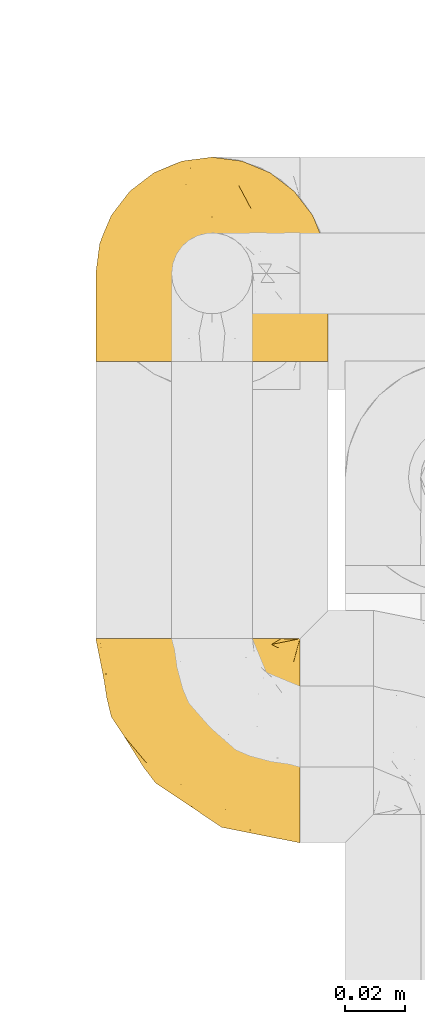
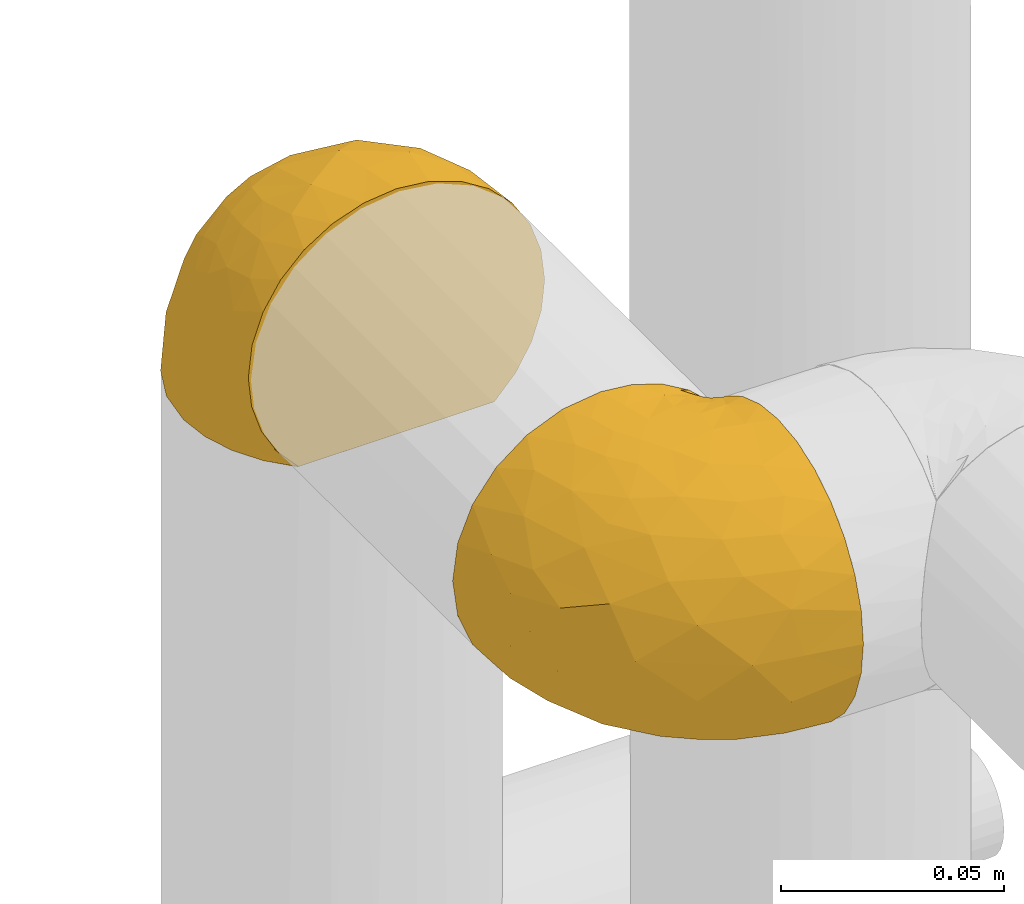
# One storey, part 83 of 827: 2 coverings.
"""IFC2X3 building model written with IfcOpenShell, lengths in millimetres."""

from ifc_helpers import new_model, entity, si_unit, converted_unit, derived_unit, direction, frame, origin, place, context, subcontext, project, spatial, faceted_brep, element, save


model = new_model("IFC2X3")

# Units and contexts
model_context = context("Model", 3, precision=0.01, world=origin(), true_north=direction((6.12303176911189e-17, 1.0)))
body_context = subcontext(model_context, "Body", "Model", "MODEL_VIEW")
ifc_project = project(units=[si_unit("LENGTHUNIT", "METRE", prefix="MILLI"), si_unit("AREAUNIT", "SQUARE_METRE"), si_unit("VOLUMEUNIT", "CUBIC_METRE"), converted_unit("PLANEANGLEUNIT", "DEGREE", entity("IfcRatioMeasure", 0.0174532925199433), si_unit("PLANEANGLEUNIT", "RADIAN"), dimensions=[0, 0, 0, 0, 0, 0, 0]), si_unit("MASSUNIT", "GRAM", prefix="KILO"), derived_unit("MASSDENSITYUNIT", [(si_unit("MASSUNIT", "GRAM", prefix="KILO"), 1), (si_unit("LENGTHUNIT", "METRE"), -3)]), derived_unit("MOMENTOFINERTIAUNIT", [(si_unit("LENGTHUNIT", "METRE"), 4)]), si_unit("TIMEUNIT", "SECOND"), si_unit("FREQUENCYUNIT", "HERTZ"), si_unit("THERMODYNAMICTEMPERATUREUNIT", "DEGREE_CELSIUS"), derived_unit("THERMALTRANSMITTANCEUNIT", [(si_unit("MASSUNIT", "GRAM", prefix="KILO"), 1), (si_unit("THERMODYNAMICTEMPERATUREUNIT", "KELVIN"), -1), (si_unit("TIMEUNIT", "SECOND"), -3)]), derived_unit("VOLUMETRICFLOWRATEUNIT", [(si_unit("LENGTHUNIT", "METRE"), 3), (si_unit("TIMEUNIT", "SECOND"), -1)]), derived_unit("MASSFLOWRATEUNIT", [(si_unit("MASSUNIT", "GRAM", prefix="KILO"), 1), (si_unit("TIMEUNIT", "SECOND"), -1)]), derived_unit("ROTATIONALFREQUENCYUNIT", [(si_unit("TIMEUNIT", "SECOND"), -1)]), si_unit("ELECTRICCURRENTUNIT", "AMPERE"), si_unit("ELECTRICVOLTAGEUNIT", "VOLT"), si_unit("POWERUNIT", "WATT"), si_unit("FORCEUNIT", "NEWTON", prefix="KILO"), si_unit("ILLUMINANCEUNIT", "LUX"), si_unit("LUMINOUSFLUXUNIT", "LUMEN"), si_unit("LUMINOUSINTENSITYUNIT", "CANDELA"), derived_unit("USERDEFINED", [(si_unit("MASSUNIT", "GRAM", prefix="KILO"), -1), (si_unit("LENGTHUNIT", "METRE"), -2), (si_unit("TIMEUNIT", "SECOND"), 3), (si_unit("LUMINOUSFLUXUNIT", "LUMEN"), 1)]), derived_unit("LINEARVELOCITYUNIT", [(si_unit("LENGTHUNIT", "METRE"), 1), (si_unit("TIMEUNIT", "SECOND"), -1)]), si_unit("PRESSUREUNIT", "PASCAL"), derived_unit("USERDEFINED", [(si_unit("LENGTHUNIT", "METRE"), -2), (si_unit("MASSUNIT", "GRAM", prefix="KILO"), 1), (si_unit("TIMEUNIT", "SECOND"), -2)]), derived_unit("LINEARFORCEUNIT", [(si_unit("MASSUNIT", "GRAM", prefix="KILO"), 1), (si_unit("LENGTHUNIT", "METRE"), 1), (si_unit("TIMEUNIT", "SECOND"), -2), (si_unit("LENGTHUNIT", "METRE"), -1)]), derived_unit("PLANARFORCEUNIT", [(si_unit("MASSUNIT", "GRAM", prefix="KILO"), 1), (si_unit("LENGTHUNIT", "METRE"), 1), (si_unit("TIMEUNIT", "SECOND"), -2), (si_unit("LENGTHUNIT", "METRE"), -2)])], contexts=[model_context])

# Site, building, storey
site_placement = place(None, origin())
site = spatial("IfcSite", under=ifc_project, at=site_placement, CompositionType="ELEMENT")
building_placement = place(site_placement, origin())
building = spatial("IfcBuilding", under=site, at=building_placement, CompositionType="ELEMENT")
storey_placement = place(building_placement, frame((0.0, 0.0, 28200.0)))
storey = spatial("IfcBuildingStorey", under=building, at=storey_placement, Name="08", CompositionType="ELEMENT", Elevation=28200.0)

# Coverings
covering_1_placement = place(storey_placement, frame((19653.72, 11698.51, 1518.12)))
element("IfcCovering", 1, at=covering_1_placement, inside=storey, Name=":ADSK_", ObjectType=":ADSK_", PredefinedType="INSULATION", context=body_context, shape_type="Brep", body=[
    faceted_brep([(69.15, 23.36, 74.68), (69.15, 16.07, 70.1), (69.15, 9.98, 64.01), (69.15, 5.4, 56.72), (69.15, 2.56, 48.6), (69.15, 1.6, 40.05), (69.15, 2.56, 31.49), (69.15, 5.41, 23.36), (69.15, 9.99, 16.07), (69.15, 16.08, 9.98), (69.15, 23.37, 5.4), (69.15, 31.49, 2.56), (69.15, 40.05, 1.6), (69.15, 48.15, 2.46), (69.15, 55.88, 5.01), (69.15, 62.9, 9.13), (69.15, 68.89, 14.62), (69.15, 68.89, 16.82), (69.15, 68.89, 18.56), (69.15, 68.89, 20.52), (69.15, 68.89, 22.49), (69.15, 68.89, 24.46), (69.15, 68.89, 26.42), (69.15, 68.89, 28.39), (69.15, 68.89, 30.36), (69.15, 68.89, 32.55), (69.15, 68.89, 34.75), (69.15, 68.89, 36.94), (69.15, 68.89, 39.13), (69.15, 68.89, 41.33), (69.15, 68.89, 43.52), (69.15, 68.89, 45.72), (69.15, 68.89, 47.91), (69.15, 68.89, 50.11), (69.15, 68.89, 52.3), (69.15, 68.89, 54.49), (69.15, 68.89, 56.69), (69.15, 68.89, 58.88), (69.15, 68.89, 61.08), (69.15, 68.89, 63.27), (69.15, 68.89, 65.47), (69.15, 62.89, 70.97), (69.15, 55.86, 75.09), (69.15, 48.13, 77.64), (69.15, 40.05, 78.5), (69.15, 31.49, 77.53), (68.89, 69.15, 14.62), (62.89, 69.15, 9.12), (55.87, 69.15, 5.0), (48.14, 69.15, 2.46), (40.05, 69.15, 1.6), (30.09, 69.15, 2.91), (20.82, 69.15, 6.75), (12.86, 69.15, 12.86), (6.75, 69.15, 20.82), (2.91, 69.15, 30.09), (1.6, 69.15, 40.05), (2.91, 69.15, 50.0), (6.75, 69.15, 59.27), (12.86, 69.15, 67.23), (20.82, 69.15, 73.34), (30.09, 69.15, 77.19), (40.05, 69.15, 78.5), (48.14, 69.15, 77.63), (55.87, 69.15, 75.09), (62.89, 69.15, 70.97), (68.89, 69.15, 65.47), (68.89, 69.15, 63.27), (68.89, 69.15, 62.29), (68.89, 69.15, 60.7), (68.89, 69.15, 59.11), (68.89, 69.15, 57.52), (68.89, 69.15, 55.93), (68.89, 69.15, 54.34), (68.89, 69.15, 52.76), (68.89, 69.15, 51.17), (68.89, 69.15, 49.58), (68.89, 69.15, 47.99), (68.89, 69.15, 46.4), (68.89, 69.15, 44.81), (68.89, 69.15, 43.22), (68.89, 69.15, 41.63), (68.89, 69.15, 40.05), (68.89, 69.15, 38.46), (68.89, 69.15, 36.87), (68.89, 69.15, 35.28), (68.89, 69.15, 33.69), (68.89, 69.15, 32.1), (68.89, 69.15, 30.51), (68.89, 69.15, 28.92), (68.89, 69.15, 27.33), (68.89, 69.15, 25.37), (68.89, 69.15, 23.4), (68.89, 69.15, 21.21), (68.89, 69.15, 19.01), (68.89, 69.15, 16.82), (68.97, 68.96, 42.32), (68.96, 68.97, 44.02), (68.97, 68.97, 47.13), (68.97, 68.97, 48.74), (68.98, 68.95, 23.57), (68.97, 68.96, 25.13), (68.96, 68.98, 61.34), (68.96, 68.97, 22.02), (68.96, 68.97, 29.72), (68.96, 68.98, 56.73), (68.96, 68.97, 55.14), (68.96, 68.97, 37.66), (69.0, 68.94, 64.12), (68.96, 68.98, 28.13), (68.96, 68.98, 26.62), (68.97, 68.96, 31.46), (68.96, 68.97, 16.16), (68.96, 68.98, 39.16), (68.96, 68.98, 50.37), (68.97, 68.97, 17.69), (68.97, 68.96, 19.17), (68.97, 68.97, 62.78), (68.96, 68.97, 58.35), (68.96, 68.98, 45.53), (68.97, 68.96, 59.91), (68.97, 68.97, 65.47), (69.02, 68.94, 65.47), (69.08, 68.92, 65.47), (68.97, 68.97, 14.62), (68.94, 69.02, 14.62), (68.92, 69.08, 14.62), (68.96, 68.98, 20.59), (68.96, 68.97, 32.99), (68.95, 68.98, 34.48), (68.96, 68.97, 51.91), (68.92, 69.08, 65.47), (68.94, 69.02, 65.47), (68.98, 68.96, 53.48), (69.08, 68.92, 14.62), (69.02, 68.94, 14.62), (68.96, 68.97, 40.77), (68.97, 68.96, 35.97), (61.33, 67.02, 7.84), (53.1, 63.33, 3.53), (63.33, 64.61, 8.32), (49.27, 49.27, 1.6), (55.53, 51.4, 2.19), (54.6, 43.94, 1.6), (41.99, 61.87, 1.6), (57.07, 61.54, 4.57), (57.95, 57.95, 3.96), (51.56, 56.12, 2.28), (41.58, 63.4, 1.6), (61.7, 65.41, 7.69), (63.33, 53.1, 3.53), (65.0, 63.04, 8.32), (67.02, 61.33, 7.84), (61.87, 41.99, 1.6), (43.94, 54.6, 1.6), (61.21, 56.6, 4.34), (63.4, 41.58, 1.6), (33.11, 13.72, 29.63), (52.82, 5.82, 27.34), (43.3, 6.74, 40.05), (33.73, 58.82, 2.39), (36.52, 51.58, 2.43), (24.87, 42.09, 9.07), (14.17, 46.12, 16.64), (18.43, 55.56, 9.54), (28.67, 52.38, 4.52), (26.0, 61.54, 4.52), (49.25, 23.76, 7.49), (59.72, 20.5, 7.49), (55.1, 14.64, 12.85), (44.72, 41.77, 2.35), (34.15, 16.28, 22.66), (5.25, 49.4, 32.9), (6.75, 52.34, 25.33), (55.54, 4.3, 40.05), (10.47, 58.67, 16.64), (25.49, 25.26, 19.99), (35.53, 20.17, 16.37), (48.22, 34.7, 3.26), (58.71, 28.67, 3.75), (57.42, 8.62, 19.58), (34.84, 33.37, 7.5), (36.87, 41.35, 4.04), (45.01, 17.15, 13.94), (44.4, 12.68, 19.58), (23.96, 21.47, 28.21), (11.2, 41.11, 24.75), (10.56, 37.53, 31.42), (16.81, 30.64, 26.2), (17.38, 26.66, 33.36), (21.38, 21.38, 40.05), (32.34, 14.06, 40.05), (4.3, 55.54, 40.05), (20.65, 35.17, 16.14), (29.66, 29.04, 12.85), (39.6, 24.34, 10.47), (42.55, 29.33, 6.49), (6.74, 43.3, 40.05), (14.06, 32.34, 40.05), (26.84, 57.75, 75.57), (5.28, 49.41, 47.37), (18.52, 27.85, 52.91), (33.13, 13.7, 50.46), (55.1, 14.63, 67.23), (57.43, 8.61, 60.5), (20.72, 48.85, 70.55), (11.46, 54.13, 63.45), (17.69, 37.84, 62.61), (49.26, 23.75, 72.6), (59.73, 20.49, 72.6), (58.71, 28.66, 76.34), (29.72, 20.83, 59.34), (35.35, 55.15, 77.76), (43.94, 54.6, 78.5), (41.99, 61.87, 78.5), (63.4, 41.58, 78.5), (4.93, 57.58, 53.16), (17.46, 59.91, 70.55), (10.94, 36.94, 48.88), (8.92, 45.72, 54.76), (52.83, 5.82, 52.74), (29.34, 37.91, 71.93), (30.26, 50.18, 75.79), (44.4, 12.67, 60.5), (39.06, 49.29, 77.86), (43.06, 42.64, 77.64), (54.6, 43.94, 78.5), (49.27, 49.27, 78.5), (42.69, 19.45, 67.23), (48.2, 34.7, 76.82), (61.87, 41.99, 78.5), (33.44, 62.29, 77.8), (29.67, 29.01, 67.23), (38.5, 31.47, 73.2), (23.35, 37.18, 67.66), (34.97, 43.45, 75.99), (53.1, 63.33, 76.57), (59.68, 67.23, 73.21), (62.19, 66.07, 71.93), (64.11, 65.22, 71.07), (57.97, 61.99, 75.09), (57.95, 57.95, 76.13), (63.33, 53.09, 76.57), (51.77, 56.84, 77.69), (67.02, 61.33, 72.26), (64.98, 63.06, 71.77), (55.53, 51.41, 77.9), (61.22, 56.61, 75.75)], [[[0, 1, 2, 3, 4, 5, 6, 7, 8, 9, 10, 11, 12, 13, 14, 15, 16, 17, 18, 19, 20, 21, 22, 23, 24, 25, 26, 27, 28, 29, 30, 31, 32, 33, 34, 35, 36, 37, 38, 39, 40, 41, 42, 43, 44, 45]], [[46, 47, 48, 49, 50, 51, 52, 53, 54, 55, 56, 57, 58, 59, 60, 61, 62, 63, 64, 65, 66, 67, 68, 69, 70, 71, 72, 73, 74, 75, 76, 77, 78, 79, 80, 81, 82, 83, 84, 85, 86, 87, 88, 89, 90, 91, 92, 93, 94, 95]], [[96, 97, 30]], [[98, 77, 99]], [[100, 101, 21]], [[69, 68, 102]], [[20, 19, 103]], [[24, 23, 104]], [[20, 103, 100]], [[72, 105, 106]], [[84, 83, 107]], [[89, 88, 104]], [[108, 67, 66]], [[109, 110, 90]], [[111, 25, 24]], [[112, 17, 16]], [[82, 113, 83]], [[109, 23, 22]], [[114, 76, 75]], [[105, 36, 106]], [[104, 111, 24]], [[18, 115, 116]], [[97, 96, 80]], [[67, 108, 117]], [[105, 71, 118]], [[31, 97, 119]], [[102, 120, 69]], [[108, 121, 122, 123, 40]], [[112, 95, 115]], [[17, 115, 18]], [[94, 116, 115]], [[117, 68, 67]], [[38, 117, 39]], [[112, 124, 125, 126, 46]], [[17, 112, 115]], [[70, 120, 118]], [[39, 117, 108]], [[120, 38, 37]], [[120, 37, 118]], [[120, 70, 69]], [[116, 94, 127]], [[128, 86, 129]], [[117, 38, 102]], [[74, 130, 75]], [[99, 33, 32]], [[115, 95, 94]], [[39, 108, 40]], [[108, 66, 131, 132, 121]], [[105, 72, 71]], [[118, 37, 36]], [[71, 70, 118]], [[35, 106, 36]], [[36, 105, 118]], [[35, 133, 106]], [[74, 73, 133]], [[106, 133, 73]], [[99, 114, 33]], [[133, 35, 34]], [[73, 72, 106]], [[95, 112, 46]], [[112, 16, 134, 135, 124]], [[130, 114, 75]], [[99, 76, 114]], [[114, 130, 33]], [[34, 33, 130]], [[78, 77, 98]], [[98, 119, 78]], [[130, 133, 34]], [[133, 130, 74]], [[79, 97, 80]], [[98, 99, 32]], [[98, 32, 31]], [[77, 76, 99]], [[97, 79, 119]], [[136, 96, 29]], [[30, 97, 31]], [[136, 29, 28]], [[81, 80, 96]], [[29, 96, 30]], [[31, 119, 98]], [[119, 79, 78]], [[96, 136, 81]], [[82, 81, 136]], [[113, 107, 83]], [[84, 107, 137]], [[107, 27, 137]], [[113, 28, 107]], [[27, 107, 28]], [[85, 84, 137]], [[137, 27, 26]], [[113, 136, 28]], [[136, 113, 82]], [[109, 89, 104]], [[86, 85, 129]], [[89, 109, 90]], [[111, 87, 128]], [[26, 129, 137]], [[88, 111, 104]], [[25, 111, 128]], [[22, 110, 109]], [[23, 109, 104]], [[110, 91, 90]], [[100, 92, 101]], [[110, 22, 101]], [[91, 110, 101]], [[116, 19, 18]], [[111, 88, 87]], [[127, 103, 19]], [[25, 128, 26]], [[86, 128, 87]], [[128, 129, 26]], [[137, 129, 85]], [[120, 102, 38]], [[117, 102, 68]], [[91, 101, 92]], [[21, 101, 22]], [[93, 92, 103]], [[100, 21, 20]], [[100, 103, 92]], [[127, 93, 103]], [[93, 127, 94]], [[116, 127, 19]], [[126, 138, 47]], [[48, 138, 139]], [[140, 125, 124]], [[141, 142, 143]], [[144, 49, 139]], [[145, 140, 146]], [[48, 139, 49]], [[139, 145, 147]], [[49, 144, 148, 50]], [[126, 125, 149]], [[14, 13, 150]], [[151, 146, 140]], [[149, 140, 145]], [[152, 151, 135]], [[152, 14, 150]], [[16, 15, 134]], [[13, 153, 150]], [[124, 151, 140]], [[141, 147, 142]], [[14, 152, 15]], [[15, 152, 134]], [[47, 46, 126]], [[139, 154, 144]], [[138, 48, 47]], [[125, 140, 149]], [[135, 134, 152]], [[146, 155, 142]], [[145, 146, 147]], [[149, 139, 138]], [[147, 141, 154]], [[147, 146, 142]], [[139, 147, 154]], [[139, 149, 145]], [[149, 138, 126]], [[155, 146, 151]], [[150, 143, 142]], [[152, 155, 151]], [[150, 142, 155]], [[13, 12, 156, 153]], [[153, 143, 150]], [[152, 150, 155]], [[151, 124, 135]], [[157, 158, 159]], [[160, 154, 161]], [[162, 163, 164]], [[165, 166, 160]], [[167, 168, 169]], [[141, 170, 161]], [[156, 12, 11]], [[158, 157, 171]], [[172, 55, 173]], [[158, 6, 174]], [[175, 54, 53]], [[52, 166, 164]], [[52, 164, 53]], [[54, 175, 173]], [[166, 52, 51]], [[176, 177, 171]], [[178, 143, 179]], [[156, 11, 179]], [[8, 7, 180]], [[169, 9, 8]], [[179, 143, 153, 156]], [[179, 11, 10]], [[168, 179, 10]], [[181, 162, 182]], [[179, 167, 178]], [[183, 184, 177]], [[183, 169, 184]], [[176, 171, 185]], [[172, 186, 187]], [[158, 7, 6]], [[159, 158, 174]], [[184, 180, 158]], [[54, 173, 55]], [[180, 169, 8]], [[188, 189, 187]], [[9, 168, 10]], [[186, 188, 187]], [[190, 157, 159, 191]], [[55, 172, 192]], [[176, 193, 194]], [[161, 170, 182]], [[162, 164, 165]], [[175, 164, 163]], [[51, 50, 148]], [[167, 195, 196]], [[178, 182, 170]], [[6, 5, 174]], [[158, 180, 7]], [[169, 180, 184]], [[169, 168, 9]], [[179, 168, 167]], [[182, 162, 165]], [[162, 194, 193]], [[161, 165, 160]], [[195, 181, 196]], [[192, 172, 197]], [[192, 56, 55]], [[189, 190, 198]], [[198, 197, 187]], [[172, 187, 197]], [[185, 189, 188]], [[198, 187, 189]], [[186, 172, 173]], [[173, 163, 186]], [[193, 186, 163]], [[176, 185, 188]], [[185, 157, 190]], [[188, 186, 193]], [[177, 176, 194]], [[188, 193, 176]], [[162, 193, 163]], [[195, 177, 194]], [[171, 177, 184]], [[181, 195, 194]], [[183, 167, 169]], [[162, 181, 194]], [[196, 182, 178]], [[158, 171, 184]], [[171, 157, 185]], [[177, 195, 183]], [[167, 183, 195]], [[182, 196, 181]], [[178, 170, 143]], [[178, 167, 196]], [[164, 175, 53]], [[173, 175, 163]], [[160, 51, 148]], [[164, 166, 165]], [[51, 160, 166]], [[160, 148, 144, 154]], [[141, 161, 154]], [[182, 165, 161]], [[190, 189, 185]], [[143, 170, 141]], [[60, 199, 61]], [[197, 200, 192]], [[201, 190, 202]], [[200, 57, 192]], [[203, 204, 2]], [[205, 206, 207]], [[208, 209, 210]], [[211, 207, 201]], [[212, 213, 214]], [[45, 215, 210]], [[216, 206, 58]], [[45, 44, 215]], [[59, 217, 60]], [[60, 217, 199]], [[0, 45, 210]], [[218, 201, 219]], [[202, 159, 220]], [[205, 221, 222]], [[223, 204, 203]], [[1, 203, 2]], [[57, 200, 216]], [[220, 3, 204]], [[220, 174, 4]], [[1, 0, 209]], [[212, 224, 213]], [[225, 226, 227]], [[228, 223, 203]], [[208, 210, 229]], [[210, 226, 229]], [[3, 220, 4]], [[58, 206, 59]], [[209, 203, 1]], [[202, 220, 223]], [[228, 203, 208]], [[202, 211, 201]], [[3, 2, 204]], [[202, 190, 191, 159]], [[210, 215, 230, 226]], [[199, 212, 231]], [[232, 233, 221]], [[233, 208, 229]], [[207, 206, 219]], [[217, 206, 205]], [[227, 224, 225]], [[233, 232, 228]], [[201, 207, 219]], [[234, 232, 221]], [[218, 219, 200]], [[202, 223, 211]], [[174, 220, 159]], [[174, 5, 4]], [[61, 231, 62]], [[220, 204, 223]], [[210, 209, 0]], [[203, 209, 208]], [[225, 233, 229]], [[224, 227, 213]], [[221, 233, 235]], [[57, 56, 192]], [[198, 218, 197]], [[200, 219, 216]], [[201, 198, 190]], [[197, 218, 200]], [[198, 201, 218]], [[206, 216, 219]], [[58, 57, 216]], [[231, 212, 214]], [[222, 212, 199]], [[228, 211, 223]], [[207, 211, 232]], [[62, 231, 214]], [[199, 231, 61]], [[233, 228, 208]], [[211, 228, 232]], [[222, 221, 235]], [[234, 205, 207]], [[206, 217, 59]], [[199, 217, 205]], [[205, 222, 199]], [[224, 222, 235]], [[222, 224, 212]], [[224, 235, 225]], [[233, 225, 235]], [[226, 225, 229]], [[205, 234, 221]], [[207, 232, 234]], [[63, 214, 236]], [[214, 213, 236]], [[214, 63, 62]], [[237, 236, 238]], [[238, 132, 131]], [[236, 237, 64]], [[239, 240, 241]], [[63, 236, 64]], [[131, 66, 65]], [[237, 131, 65]], [[242, 230, 43]], [[237, 65, 64]], [[239, 121, 132]], [[42, 242, 43]], [[241, 240, 243]], [[41, 123, 244]], [[43, 230, 215, 44]], [[244, 122, 245]], [[227, 246, 243]], [[241, 243, 246]], [[121, 239, 245]], [[41, 40, 123]], [[132, 238, 239]], [[244, 42, 41]], [[131, 237, 238]], [[240, 239, 238]], [[245, 239, 241]], [[247, 241, 246]], [[247, 244, 245]], [[238, 236, 240]], [[243, 236, 213]], [[236, 243, 240]], [[226, 246, 227]], [[243, 213, 227]], [[226, 242, 246]], [[241, 247, 245]], [[246, 242, 247]], [[244, 247, 242]], [[242, 226, 230]], [[42, 244, 242]], [[122, 244, 123]], [[122, 121, 245]]]),
])
covering_2_placement = place(storey_placement, frame((19653.72, 11857.86, 1527.47)))
element("IfcCovering", 2, at=covering_2_placement, inside=storey, Name=":ADSK_", ObjectType=":ADSK_", PredefinedType="INSULATION", context=body_context, shape_type="Brep", body=[
    faceted_brep([(74.68, 1.6, 47.38), (70.1, 1.6, 54.67), (64.01, 1.6, 60.76), (56.72, 1.6, 65.34), (48.6, 1.6, 68.18), (40.05, 1.6, 69.15), (31.49, 1.6, 68.18), (23.36, 1.6, 65.33), (16.07, 1.6, 60.75), (9.98, 1.6, 54.66), (5.4, 1.6, 47.37), (2.56, 1.6, 39.25), (1.6, 1.6, 30.7), (2.46, 1.6, 22.59), (5.01, 1.6, 14.86), (9.13, 1.6, 7.84), (14.62, 1.6, 1.85), (16.82, 1.6, 1.85), (18.56, 1.6, 1.85), (20.52, 1.6, 1.85), (22.49, 1.6, 1.85), (24.46, 1.6, 1.85), (26.42, 1.6, 1.85), (28.39, 1.6, 1.85), (30.36, 1.6, 1.85), (32.55, 1.6, 1.85), (34.75, 1.6, 1.85), (36.94, 1.6, 1.85), (39.13, 1.6, 1.85), (41.33, 1.6, 1.85), (43.52, 1.6, 1.85), (45.72, 1.6, 1.85), (47.91, 1.6, 1.85), (50.11, 1.6, 1.85), (52.3, 1.6, 1.85), (54.49, 1.6, 1.85), (56.69, 1.6, 1.85), (58.88, 1.6, 1.85), (61.08, 1.6, 1.85), (63.27, 1.6, 1.85), (65.47, 1.6, 1.85), (70.97, 1.6, 7.85), (75.09, 1.6, 14.88), (77.64, 1.6, 22.61), (78.5, 1.6, 30.7), (77.53, 1.6, 39.26), (14.62, 1.85, 1.6), (9.12, 7.85, 1.6), (5.0, 14.87, 1.6), (2.46, 22.6, 1.6), (1.6, 30.7, 1.6), (2.91, 40.65, 1.6), (6.75, 49.92, 1.6), (12.86, 57.88, 1.6), (20.82, 63.99, 1.6), (30.09, 67.84, 1.6), (40.05, 69.15, 1.6), (50.0, 67.84, 1.6), (59.27, 63.99, 1.6), (67.23, 57.88, 1.6), (73.34, 49.92, 1.6), (77.19, 40.65, 1.6), (78.5, 30.7, 1.6), (77.63, 22.6, 1.6), (75.09, 14.87, 1.6), (70.97, 7.85, 1.6), (65.47, 1.85, 1.6), (63.27, 1.85, 1.6), (62.29, 1.85, 1.6), (60.7, 1.85, 1.6), (59.11, 1.85, 1.6), (57.52, 1.85, 1.6), (55.93, 1.85, 1.6), (54.34, 1.85, 1.6), (52.76, 1.85, 1.6), (51.17, 1.85, 1.6), (49.58, 1.85, 1.6), (47.99, 1.85, 1.6), (46.4, 1.85, 1.6), (44.81, 1.85, 1.6), (43.22, 1.85, 1.6), (41.63, 1.85, 1.6), (40.05, 1.85, 1.6), (38.46, 1.85, 1.6), (36.87, 1.85, 1.6), (35.28, 1.85, 1.6), (33.69, 1.85, 1.6), (32.1, 1.85, 1.6), (30.51, 1.85, 1.6), (28.92, 1.85, 1.6), (27.33, 1.85, 1.6), (25.37, 1.85, 1.6), (23.4, 1.85, 1.6), (21.21, 1.85, 1.6), (19.01, 1.85, 1.6), (16.82, 1.85, 1.6), (42.32, 1.77, 1.78), (44.02, 1.78, 1.77), (47.13, 1.77, 1.78), (48.74, 1.77, 1.77), (23.57, 1.76, 1.79), (25.13, 1.77, 1.78), (61.34, 1.79, 1.76), (22.02, 1.78, 1.77), (29.72, 1.78, 1.77), (56.73, 1.78, 1.76), (55.14, 1.78, 1.77), (37.66, 1.78, 1.77), (64.12, 1.74, 1.8), (28.13, 1.78, 1.76), (26.62, 1.78, 1.77), (31.46, 1.77, 1.78), (16.16, 1.78, 1.77), (39.16, 1.78, 1.77), (50.37, 1.78, 1.76), (17.69, 1.77, 1.77), (19.17, 1.77, 1.78), (62.78, 1.77, 1.77), (58.35, 1.78, 1.77), (45.53, 1.78, 1.77), (59.91, 1.77, 1.78), (65.47, 1.77, 1.77), (65.47, 1.72, 1.8), (65.47, 1.66, 1.82), (14.62, 1.77, 1.77), (14.62, 1.8, 1.72), (14.62, 1.82, 1.66), (20.59, 1.79, 1.76), (32.99, 1.78, 1.77), (34.48, 1.79, 1.76), (51.91, 1.78, 1.77), (65.47, 1.82, 1.66), (65.47, 1.8, 1.72), (53.48, 1.76, 1.78), (14.62, 1.66, 1.82), (14.62, 1.72, 1.8), (40.77, 1.78, 1.77), (35.97, 1.77, 1.78), (7.84, 9.41, 3.72), (3.53, 17.65, 7.41), (8.32, 7.41, 6.13), (2.19, 15.21, 19.34), (3.53, 7.41, 17.64), (1.6, 16.15, 26.8), (1.6, 28.75, 8.87), (4.57, 13.67, 9.2), (3.96, 12.79, 12.79), (2.28, 19.18, 14.62), (1.6, 29.16, 7.34), (7.69, 9.04, 5.33), (8.32, 5.74, 7.7), (7.84, 3.72, 9.41), (1.6, 8.87, 28.75), (1.6, 21.47, 21.47), (1.6, 26.8, 16.15), (4.34, 9.53, 14.14), (1.6, 7.34, 29.16), (29.63, 37.63, 57.02), (27.34, 17.92, 64.92), (40.05, 27.45, 64.0), (2.39, 37.01, 11.92), (2.43, 34.22, 19.16), (9.07, 45.87, 28.65), (16.64, 56.57, 24.62), (9.54, 52.31, 15.19), (4.52, 42.07, 18.36), (4.52, 44.74, 9.2), (7.49, 21.49, 46.98), (7.49, 11.02, 50.24), (12.85, 15.64, 56.1), (2.35, 26.02, 28.97), (22.66, 36.59, 54.46), (32.9, 65.49, 21.34), (25.33, 63.99, 18.4), (40.05, 15.2, 66.44), (16.64, 60.27, 12.07), (19.99, 45.25, 45.49), (16.37, 35.21, 50.57), (3.26, 22.52, 36.04), (3.75, 12.03, 42.07), (19.58, 13.32, 62.12), (7.5, 35.9, 37.37), (4.04, 33.87, 29.39), (13.94, 25.73, 53.59), (19.58, 26.34, 58.06), (28.21, 46.78, 49.27), (24.75, 59.54, 29.63), (31.42, 60.18, 33.21), (26.2, 53.93, 40.1), (33.36, 53.36, 44.08), (40.05, 49.36, 49.36), (40.05, 38.4, 56.68), (40.05, 66.44, 15.2), (16.14, 50.09, 35.57), (12.85, 41.08, 41.7), (10.47, 31.14, 46.4), (6.49, 28.19, 41.41), (40.05, 64.0, 27.45), (40.05, 56.68, 38.4), (75.57, 43.9, 12.99), (47.37, 65.46, 21.33), (52.91, 52.22, 42.89), (50.46, 37.61, 57.04), (67.23, 15.64, 56.11), (60.5, 13.31, 62.13), (70.55, 50.02, 21.89), (63.45, 59.28, 16.62), (62.61, 53.05, 32.9), (72.6, 21.48, 46.99), (72.6, 11.01, 50.25), (76.34, 12.03, 42.08), (59.34, 41.02, 49.91), (77.76, 35.39, 15.6), (78.5, 26.8, 16.15), (78.5, 28.75, 8.87), (78.5, 7.34, 29.16), (53.16, 65.81, 13.16), (70.55, 53.28, 10.83), (48.88, 59.8, 33.8), (54.76, 61.82, 25.02), (52.74, 17.91, 64.92), (71.93, 41.4, 32.83), (75.79, 40.48, 20.56), (60.5, 26.34, 58.07), (77.86, 31.68, 21.46), (77.64, 27.68, 28.1), (78.5, 16.15, 26.8), (78.5, 21.47, 21.47), (67.23, 28.05, 51.29), (76.82, 22.54, 36.04), (78.5, 8.87, 28.75), (77.8, 37.3, 8.45), (67.23, 41.07, 41.73), (73.2, 32.24, 39.27), (67.66, 47.4, 33.56), (75.99, 35.77, 27.29), (76.57, 17.65, 7.41), (73.21, 11.06, 3.51), (71.93, 8.55, 4.68), (71.07, 6.63, 5.52), (75.09, 12.77, 8.75), (76.13, 12.79, 12.79), (76.57, 7.41, 17.65), (77.69, 18.97, 13.9), (72.26, 3.72, 9.42), (71.77, 5.76, 7.68), (77.9, 15.21, 19.33), (75.75, 9.52, 14.13)], [[[0, 1, 2, 3, 4, 5, 6, 7, 8, 9, 10, 11, 12, 13, 14, 15, 16, 17, 18, 19, 20, 21, 22, 23, 24, 25, 26, 27, 28, 29, 30, 31, 32, 33, 34, 35, 36, 37, 38, 39, 40, 41, 42, 43, 44, 45]], [[46, 47, 48, 49, 50, 51, 52, 53, 54, 55, 56, 57, 58, 59, 60, 61, 62, 63, 64, 65, 66, 67, 68, 69, 70, 71, 72, 73, 74, 75, 76, 77, 78, 79, 80, 81, 82, 83, 84, 85, 86, 87, 88, 89, 90, 91, 92, 93, 94, 95]], [[96, 97, 30]], [[98, 77, 99]], [[100, 101, 21]], [[69, 68, 102]], [[20, 19, 103]], [[24, 23, 104]], [[20, 103, 100]], [[72, 105, 106]], [[84, 83, 107]], [[89, 88, 104]], [[108, 67, 66]], [[109, 110, 90]], [[111, 25, 24]], [[112, 17, 16]], [[82, 113, 83]], [[109, 23, 22]], [[114, 76, 75]], [[105, 36, 106]], [[104, 111, 24]], [[18, 115, 116]], [[97, 96, 80]], [[67, 108, 117]], [[105, 71, 118]], [[31, 97, 119]], [[102, 120, 69]], [[108, 121, 122, 123, 40]], [[112, 95, 115]], [[17, 115, 18]], [[94, 116, 115]], [[117, 68, 67]], [[38, 117, 39]], [[112, 124, 125, 126, 46]], [[17, 112, 115]], [[70, 120, 118]], [[39, 117, 108]], [[120, 38, 37]], [[120, 37, 118]], [[120, 70, 69]], [[116, 94, 127]], [[128, 86, 129]], [[117, 38, 102]], [[74, 130, 75]], [[99, 33, 32]], [[115, 95, 94]], [[39, 108, 40]], [[108, 66, 131, 132, 121]], [[105, 72, 71]], [[118, 37, 36]], [[71, 70, 118]], [[35, 106, 36]], [[36, 105, 118]], [[35, 133, 106]], [[74, 73, 133]], [[106, 133, 73]], [[99, 114, 33]], [[133, 35, 34]], [[73, 72, 106]], [[95, 112, 46]], [[112, 16, 134, 135, 124]], [[130, 114, 75]], [[99, 76, 114]], [[114, 130, 33]], [[34, 33, 130]], [[78, 77, 98]], [[98, 119, 78]], [[130, 133, 34]], [[133, 130, 74]], [[79, 97, 80]], [[98, 99, 32]], [[98, 32, 31]], [[77, 76, 99]], [[97, 79, 119]], [[136, 96, 29]], [[30, 97, 31]], [[136, 29, 28]], [[81, 80, 96]], [[29, 96, 30]], [[31, 119, 98]], [[119, 79, 78]], [[96, 136, 81]], [[82, 81, 136]], [[113, 107, 83]], [[84, 107, 137]], [[107, 27, 137]], [[113, 28, 107]], [[27, 107, 28]], [[85, 84, 137]], [[137, 27, 26]], [[113, 136, 28]], [[136, 113, 82]], [[109, 89, 104]], [[86, 85, 129]], [[89, 109, 90]], [[111, 87, 128]], [[26, 129, 137]], [[88, 111, 104]], [[25, 111, 128]], [[22, 110, 109]], [[23, 109, 104]], [[110, 91, 90]], [[100, 92, 101]], [[110, 22, 101]], [[91, 110, 101]], [[116, 19, 18]], [[111, 88, 87]], [[127, 103, 19]], [[25, 128, 26]], [[86, 128, 87]], [[128, 129, 26]], [[137, 129, 85]], [[120, 102, 38]], [[117, 102, 68]], [[91, 101, 92]], [[21, 101, 22]], [[93, 92, 103]], [[100, 21, 20]], [[100, 103, 92]], [[127, 93, 103]], [[93, 127, 94]], [[116, 127, 19]], [[126, 138, 47]], [[48, 138, 139]], [[140, 125, 124]], [[141, 142, 143]], [[144, 49, 139]], [[145, 140, 146]], [[48, 139, 49]], [[139, 145, 147]], [[49, 144, 148, 50]], [[126, 125, 149]], [[14, 13, 142]], [[150, 146, 140]], [[149, 140, 145]], [[151, 150, 135]], [[151, 14, 142]], [[16, 15, 134]], [[13, 152, 142]], [[124, 150, 140]], [[141, 143, 153]], [[14, 151, 15]], [[15, 151, 134]], [[47, 46, 126]], [[139, 154, 144]], [[138, 48, 47]], [[125, 140, 149]], [[135, 134, 151]], [[146, 155, 141]], [[145, 146, 147]], [[149, 139, 138]], [[147, 153, 154]], [[147, 146, 141]], [[139, 147, 154]], [[139, 149, 145]], [[149, 138, 126]], [[147, 141, 153]], [[146, 150, 155]], [[151, 155, 150]], [[142, 141, 155]], [[13, 12, 156, 152]], [[152, 143, 142]], [[151, 142, 155]], [[150, 124, 135]], [[157, 158, 159]], [[160, 154, 161]], [[162, 163, 164]], [[165, 166, 160]], [[167, 168, 169]], [[153, 170, 161]], [[156, 12, 11]], [[158, 157, 171]], [[172, 55, 173]], [[158, 6, 174]], [[175, 54, 53]], [[52, 166, 164]], [[52, 164, 53]], [[54, 175, 173]], [[166, 52, 51]], [[176, 177, 171]], [[178, 143, 179]], [[156, 11, 179]], [[8, 7, 180]], [[169, 9, 8]], [[179, 143, 152, 156]], [[179, 11, 10]], [[168, 179, 10]], [[181, 162, 182]], [[179, 167, 178]], [[183, 184, 177]], [[183, 169, 184]], [[176, 171, 185]], [[172, 186, 187]], [[158, 7, 6]], [[159, 158, 174]], [[184, 180, 158]], [[54, 173, 55]], [[180, 169, 8]], [[188, 189, 187]], [[9, 168, 10]], [[186, 188, 187]], [[190, 157, 159, 191]], [[55, 172, 192]], [[176, 193, 194]], [[161, 170, 182]], [[162, 164, 165]], [[175, 164, 163]], [[51, 50, 148]], [[167, 195, 196]], [[178, 182, 170]], [[6, 5, 174]], [[158, 180, 7]], [[169, 180, 184]], [[169, 168, 9]], [[179, 168, 167]], [[182, 162, 165]], [[162, 194, 193]], [[161, 165, 160]], [[195, 181, 196]], [[192, 172, 197]], [[192, 56, 55]], [[189, 190, 198]], [[198, 197, 187]], [[172, 187, 197]], [[185, 189, 188]], [[198, 187, 189]], [[186, 172, 173]], [[173, 163, 186]], [[193, 186, 163]], [[176, 185, 188]], [[185, 157, 190]], [[188, 186, 193]], [[177, 176, 194]], [[188, 193, 176]], [[162, 193, 163]], [[195, 177, 194]], [[171, 177, 184]], [[181, 195, 194]], [[183, 167, 169]], [[162, 181, 194]], [[196, 182, 178]], [[158, 171, 184]], [[171, 157, 185]], [[177, 195, 183]], [[167, 183, 195]], [[182, 196, 181]], [[178, 170, 143]], [[178, 167, 196]], [[164, 175, 53]], [[173, 175, 163]], [[160, 51, 148]], [[164, 166, 165]], [[51, 160, 166]], [[160, 148, 144, 154]], [[153, 161, 154]], [[182, 165, 161]], [[190, 189, 185]], [[143, 170, 153]], [[60, 199, 61]], [[197, 200, 192]], [[201, 190, 202]], [[200, 57, 192]], [[203, 204, 2]], [[205, 206, 207]], [[208, 209, 210]], [[211, 207, 201]], [[212, 213, 214]], [[45, 215, 210]], [[216, 206, 58]], [[45, 44, 215]], [[59, 217, 60]], [[60, 217, 199]], [[0, 45, 210]], [[218, 201, 219]], [[202, 159, 220]], [[205, 221, 222]], [[223, 204, 203]], [[1, 203, 2]], [[57, 200, 216]], [[220, 3, 204]], [[220, 174, 4]], [[1, 0, 209]], [[212, 224, 213]], [[225, 226, 227]], [[228, 223, 203]], [[208, 210, 229]], [[210, 226, 229]], [[3, 220, 4]], [[58, 206, 59]], [[209, 203, 1]], [[202, 220, 223]], [[228, 203, 208]], [[202, 211, 201]], [[3, 2, 204]], [[202, 190, 191, 159]], [[210, 215, 230, 226]], [[199, 212, 231]], [[232, 233, 221]], [[233, 208, 229]], [[207, 206, 219]], [[217, 206, 205]], [[227, 224, 225]], [[233, 232, 228]], [[201, 207, 219]], [[234, 232, 221]], [[218, 219, 200]], [[202, 223, 211]], [[174, 220, 159]], [[174, 5, 4]], [[61, 231, 62]], [[220, 204, 223]], [[210, 209, 0]], [[203, 209, 208]], [[225, 233, 229]], [[224, 227, 213]], [[221, 233, 235]], [[57, 56, 192]], [[198, 218, 197]], [[200, 219, 216]], [[201, 198, 190]], [[197, 218, 200]], [[198, 201, 218]], [[206, 216, 219]], [[58, 57, 216]], [[231, 212, 214]], [[222, 212, 199]], [[228, 211, 223]], [[207, 211, 232]], [[62, 231, 214]], [[199, 231, 61]], [[233, 228, 208]], [[211, 228, 232]], [[222, 221, 235]], [[234, 205, 207]], [[206, 217, 59]], [[199, 217, 205]], [[205, 222, 199]], [[224, 222, 235]], [[222, 224, 212]], [[224, 235, 225]], [[233, 225, 235]], [[226, 225, 229]], [[205, 234, 221]], [[207, 232, 234]], [[63, 214, 236]], [[214, 213, 236]], [[214, 63, 62]], [[237, 236, 238]], [[238, 132, 131]], [[236, 237, 64]], [[239, 240, 241]], [[63, 236, 64]], [[131, 66, 65]], [[237, 131, 65]], [[242, 230, 43]], [[237, 65, 64]], [[239, 121, 132]], [[42, 242, 43]], [[241, 240, 243]], [[41, 123, 244]], [[43, 230, 215, 44]], [[244, 122, 245]], [[227, 246, 243]], [[241, 243, 246]], [[121, 239, 245]], [[41, 40, 123]], [[132, 238, 239]], [[244, 42, 41]], [[131, 237, 238]], [[240, 239, 238]], [[245, 239, 241]], [[247, 241, 246]], [[247, 244, 245]], [[238, 236, 240]], [[243, 236, 213]], [[236, 243, 240]], [[226, 246, 227]], [[243, 213, 227]], [[226, 242, 246]], [[241, 247, 245]], [[246, 242, 247]], [[244, 247, 242]], [[242, 226, 230]], [[42, 244, 242]], [[122, 244, 123]], [[122, 121, 245]]]),
])

save(model, "model.ifc")
